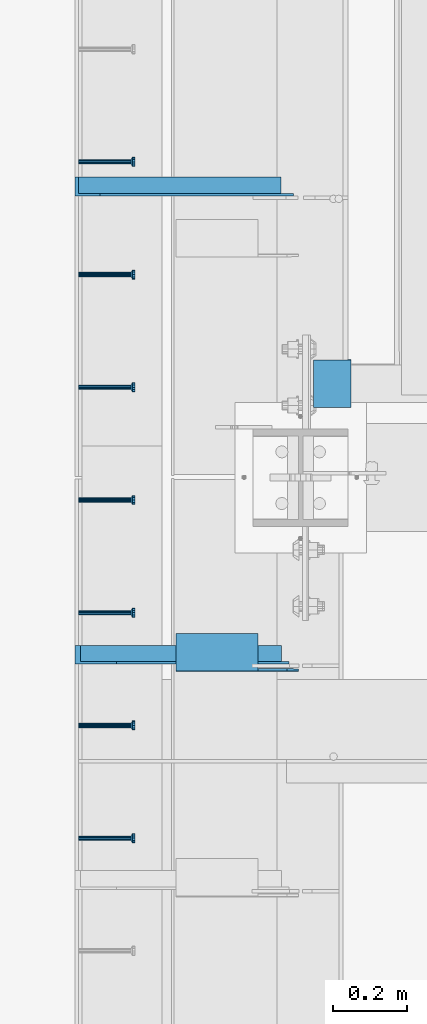
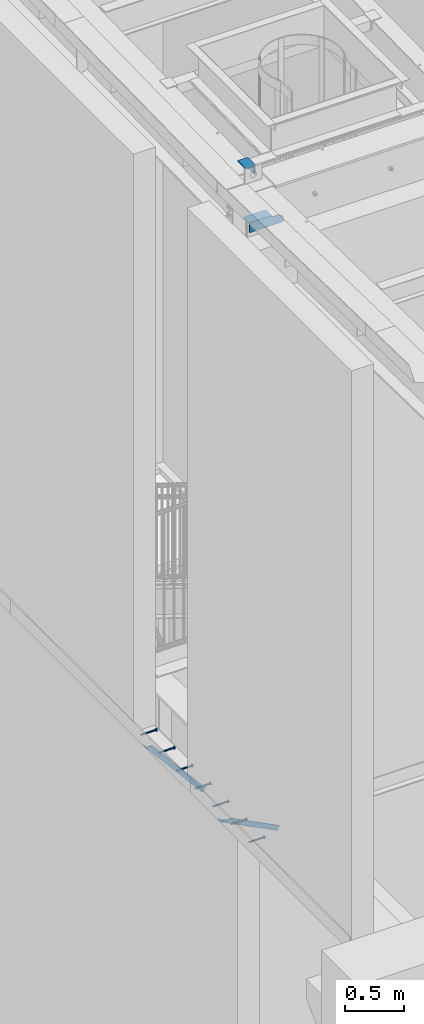
# One storey, part 1254 of 1763: 9 beams, 2 members, 11 elements without a shape of their own.
"""IFC2X3 building model written with IfcOpenShell, lengths in millimetres."""

from ifc_helpers import new_model, si_unit, frame, origin_with_axes, place, context, subcontext, project, spatial, faceted_brep, material, type_object, element, aggregate, save


model = new_model("IFC2X3")

# Units and contexts
model_context = context("Model", 3, precision=1e-05, world=origin_with_axes())
body_context = subcontext(model_context, "Body", "Model", "MODEL_VIEW")
ifc_project = project(units=[si_unit("LENGTHUNIT", "METRE", prefix="MILLI"), si_unit("AREAUNIT", "SQUARE_METRE"), si_unit("VOLUMEUNIT", "CUBIC_METRE"), si_unit("MASSUNIT", "GRAM", prefix="KILO"), si_unit("TIMEUNIT", "SECOND"), si_unit("PLANEANGLEUNIT", "RADIAN"), si_unit("SOLIDANGLEUNIT", "STERADIAN"), si_unit("THERMODYNAMICTEMPERATUREUNIT", "DEGREE_CELSIUS"), si_unit("LUMINOUSINTENSITYUNIT", "LUMEN")], contexts=[model_context])

# Site, building, storey
site_placement = place(None, origin_with_axes())
site = spatial("IfcSite", under=ifc_project, at=site_placement, CompositionType="ELEMENT")
building_placement = place(site_placement, origin_with_axes())
building = spatial("IfcBuilding", under=site, at=building_placement, Name="Undefined", CompositionType="ELEMENT")
storey_placement = place(building_placement, origin_with_axes())
storey = spatial("IfcBuildingStorey", under=building, at=storey_placement, Name="Undefined", CompositionType="ELEMENT", Elevation=0.0)

# Assembly, beam
assembly_1_placement = place(storey_placement, origin_with_axes())
assembly_1 = element("IfcElementAssembly", 1, at=assembly_1_placement, inside=storey, Name="HEADED STUD ANCHOR", AssemblyPlace="NOTDEFINED", PredefinedType="RIGID_FRAME")
ifc_material_1 = material(Name="STEEL/A108")
beam_type_1 = type_object("IfcBeamType", PredefinedType="NOTDEFINED")
beam_1_placement = place(assembly_1_placement, frame((-87975.5122736983, 29048.0750061035, 5268.91250001202), z_axis=(0.0, 0.0, -1.0), x_axis=(1.0, 0.0, 0.0)))
beam_1 = element("IfcBeam", 2, at=beam_1_placement, type_object=beam_type_1, material=ifc_material_1, Name="HEADED STUD ANCHOR", context=body_context, shape_type="Brep", body=[
    faceted_brep([(0.0, -3.1800000667572, 5.5), (0.0, -5.5, 3.1800000667572), (141.732000000002, -5.5, 3.1800000667572), (141.732000000002, -3.1800000667572, 5.5), (0.0, -6.34999999999491, 1.45519152283669e-11), (141.732000000002, -6.34999990463257, 0.0), (0.0, -5.5, -3.1800000667572), (141.732000000002, -5.5, -3.1800000667572), (0.0, -3.1800000667572, -5.5), (141.732000000002, -3.1800000667572, -5.5), (0.0, 0.0, -6.34999990463257), (141.732000000002, 0.0, -6.34999990463257), (0.0, 3.1800000667572, -5.5), (141.732000000002, 3.1800000667572, -5.5), (0.0, 5.5, -3.1800000667572), (141.732000000002, 5.5, -3.1800000667572), (0.0, 6.34999999999491, -2.91038304567337e-11), (141.732000000002, 6.34999990463257, 0.0), (0.0, 5.5, 3.1800000667572), (141.732000000002, 5.5, 3.1800000667572), (0.0, 3.1800000667572, 5.5), (141.732000000002, 3.1800000667572, 5.5), (0.0, 0.0, 6.34999990463257), (141.732000000002, 0.0, 6.34999990463257), (144.780000000001, -10.9899997711182, 6.34999990463257), (144.780000000001, -6.34000015258789, 10.9899997711182), (144.780000000001, -12.6999998092651, 0.0), (144.780000000001, -10.9899997711182, -6.34999990463257), (144.780000000001, -6.34000015258789, -10.9899997711182), (144.780000000001, 0.0, -12.6899995803833), (144.780000000001, 6.34000015258789, -10.9899997711182), (144.780000000001, 10.9899997711182, -6.34999990463257), (144.780000000001, 12.6999998092651, 0.0), (144.780000000001, 10.9899997711182, 6.34999990463257), (144.780000000001, 6.34000015258789, 10.9899997711182), (144.780000000001, 0.0, 12.6899995803833), (152.400000000001, -10.9899997711182, 6.34999990463257), (152.400000000001, -6.34000015258789, 10.9899997711182), (152.400000000001, -12.6999998092651, 0.0), (152.400000000001, -10.9899997711182, -6.34999990463257), (152.400000000001, -6.34000015258789, -10.9899997711182), (152.400000000001, 0.0, -12.6899995803833), (152.400000000001, 6.34000015258789, -10.9899997711182), (152.400000000001, 10.9899997711182, -6.34999990463257), (152.400000000001, 12.6999998092651, 0.0), (152.400000000001, 10.9899997711182, 6.34999990463257), (152.400000000001, 6.34000015258789, 10.9899997711182), (152.400000000001, 0.0, 12.6899995803833)], [[[0, 1, 2, 3]], [[1, 4, 5, 2]], [[4, 6, 7, 5]], [[6, 8, 9, 7]], [[8, 10, 11, 9]], [[10, 12, 13, 11]], [[12, 14, 15, 13]], [[14, 16, 17, 15]], [[16, 18, 19, 17]], [[18, 20, 21, 19]], [[20, 22, 23, 21]], [[22, 0, 3, 23]], [[22, 20, 18, 16, 14, 12, 10, 8, 6, 4, 1, 0]], [[3, 2, 24, 25]], [[2, 5, 26, 24]], [[5, 7, 27, 26]], [[7, 9, 28, 27]], [[9, 11, 29, 28]], [[11, 13, 30, 29]], [[13, 15, 31, 30]], [[15, 17, 32, 31]], [[17, 19, 33, 32]], [[19, 21, 34, 33]], [[21, 23, 35, 34]], [[23, 3, 25, 35]], [[25, 24, 36, 37]], [[24, 26, 38, 36]], [[26, 27, 39, 38]], [[27, 28, 40, 39]], [[28, 29, 41, 40]], [[29, 30, 42, 41]], [[30, 31, 43, 42]], [[31, 32, 44, 43]], [[32, 33, 45, 44]], [[33, 34, 46, 45]], [[34, 35, 47, 46]], [[35, 25, 37, 47]], [[38, 39, 40, 41, 42, 43, 44, 45, 46, 47, 37, 36]]]),
])
aggregate(assembly_1, [beam_1])

assembly_2_placement = place(storey_placement, origin_with_axes())
assembly_2 = element("IfcElementAssembly", 3, at=assembly_2_placement, inside=storey, Name="HEADED STUD ANCHOR", AssemblyPlace="NOTDEFINED", PredefinedType="RIGID_FRAME")
beam_2_placement = place(assembly_2_placement, frame((-87975.5122736983, 29352.8750061035, 5268.91250001202), z_axis=(0.0, 0.0, -1.0), x_axis=(1.0, 0.0, 0.0)))
beam_2 = element("IfcBeam", 4, at=beam_2_placement, type_object=beam_type_1, material=ifc_material_1, Name="HEADED STUD ANCHOR", context=body_context, shape_type="Brep", body=[
    faceted_brep([(0.0, -3.1800000667572, 5.5), (0.0, -5.5, 3.1800000667572), (141.732000000002, -5.5, 3.1800000667572), (141.732000000002, -3.1800000667572, 5.5), (0.0, -6.34999999999491, 1.45519152283669e-11), (141.732000000002, -6.34999990463257, 0.0), (0.0, -5.5, -3.1800000667572), (141.732000000002, -5.5, -3.1800000667572), (0.0, -3.1800000667572, -5.5), (141.732000000002, -3.1800000667572, -5.5), (0.0, 0.0, -6.34999990463257), (141.732000000002, 0.0, -6.34999990463257), (0.0, 3.1800000667572, -5.5), (141.732000000002, 3.1800000667572, -5.5), (0.0, 5.5, -3.1800000667572), (141.732000000002, 5.5, -3.1800000667572), (0.0, 6.34999999999491, -2.91038304567337e-11), (141.732000000002, 6.34999990463257, 0.0), (0.0, 5.5, 3.1800000667572), (141.732000000002, 5.5, 3.1800000667572), (0.0, 3.1800000667572, 5.5), (141.732000000002, 3.1800000667572, 5.5), (0.0, 0.0, 6.34999990463257), (141.732000000002, 0.0, 6.34999990463257), (144.780000000001, -10.9899997711182, 6.34999990463257), (144.780000000001, -6.34000015258789, 10.9899997711182), (144.780000000001, -12.6999998092651, 0.0), (144.780000000001, -10.9899997711182, -6.34999990463257), (144.780000000001, -6.34000015258789, -10.9899997711182), (144.780000000001, 0.0, -12.6899995803833), (144.780000000001, 6.34000015258789, -10.9899997711182), (144.780000000001, 10.9899997711182, -6.34999990463257), (144.780000000001, 12.6999998092651, 0.0), (144.780000000001, 10.9899997711182, 6.34999990463257), (144.780000000001, 6.34000015258789, 10.9899997711182), (144.780000000001, 0.0, 12.6899995803833), (152.400000000001, -10.9899997711182, 6.34999990463257), (152.400000000001, -6.34000015258789, 10.9899997711182), (152.400000000001, -12.6999998092651, 0.0), (152.400000000001, -10.9899997711182, -6.34999990463257), (152.400000000001, -6.34000015258789, -10.9899997711182), (152.400000000001, 0.0, -12.6899995803833), (152.400000000001, 6.34000015258789, -10.9899997711182), (152.400000000001, 10.9899997711182, -6.34999990463257), (152.400000000001, 12.6999998092651, 0.0), (152.400000000001, 10.9899997711182, 6.34999990463257), (152.400000000001, 6.34000015258789, 10.9899997711182), (152.400000000001, 0.0, 12.6899995803833)], [[[0, 1, 2, 3]], [[1, 4, 5, 2]], [[4, 6, 7, 5]], [[6, 8, 9, 7]], [[8, 10, 11, 9]], [[10, 12, 13, 11]], [[12, 14, 15, 13]], [[14, 16, 17, 15]], [[16, 18, 19, 17]], [[18, 20, 21, 19]], [[20, 22, 23, 21]], [[22, 0, 3, 23]], [[22, 20, 18, 16, 14, 12, 10, 8, 6, 4, 1, 0]], [[3, 2, 24, 25]], [[2, 5, 26, 24]], [[5, 7, 27, 26]], [[7, 9, 28, 27]], [[9, 11, 29, 28]], [[11, 13, 30, 29]], [[13, 15, 31, 30]], [[15, 17, 32, 31]], [[17, 19, 33, 32]], [[19, 21, 34, 33]], [[21, 23, 35, 34]], [[23, 3, 25, 35]], [[25, 24, 36, 37]], [[24, 26, 38, 36]], [[26, 27, 39, 38]], [[27, 28, 40, 39]], [[28, 29, 41, 40]], [[29, 30, 42, 41]], [[30, 31, 43, 42]], [[31, 32, 44, 43]], [[32, 33, 45, 44]], [[33, 34, 46, 45]], [[34, 35, 47, 46]], [[35, 25, 37, 47]], [[38, 39, 40, 41, 42, 43, 44, 45, 46, 47, 37, 36]]]),
])
aggregate(assembly_2, [beam_2])

assembly_3_placement = place(storey_placement, origin_with_axes())
assembly_3 = element("IfcElementAssembly", 5, at=assembly_3_placement, inside=storey, Name="HEADED STUD ANCHOR", AssemblyPlace="NOTDEFINED", PredefinedType="RIGID_FRAME")
beam_3_placement = place(assembly_3_placement, frame((-87975.5122736983, 29657.6750061035, 5268.91250001202), z_axis=(0.0, 0.0, -1.0), x_axis=(1.0, 0.0, 0.0)))
beam_3 = element("IfcBeam", 6, at=beam_3_placement, type_object=beam_type_1, material=ifc_material_1, Name="HEADED STUD ANCHOR", context=body_context, shape_type="Brep", body=[
    faceted_brep([(0.0, -3.1800000667572, 5.5), (0.0, -5.5, 3.1800000667572), (141.732000000002, -5.5, 3.1800000667572), (141.732000000002, -3.1800000667572, 5.5), (0.0, -6.34999999999491, 1.45519152283669e-11), (141.732000000002, -6.34999990463257, 0.0), (0.0, -5.5, -3.1800000667572), (141.732000000002, -5.5, -3.1800000667572), (0.0, -3.1800000667572, -5.5), (141.732000000002, -3.1800000667572, -5.5), (0.0, 0.0, -6.34999990463257), (141.732000000002, 0.0, -6.34999990463257), (0.0, 3.1800000667572, -5.5), (141.732000000002, 3.1800000667572, -5.5), (0.0, 5.5, -3.1800000667572), (141.732000000002, 5.5, -3.1800000667572), (0.0, 6.34999999999491, -2.91038304567337e-11), (141.732000000002, 6.34999990463257, 0.0), (0.0, 5.5, 3.1800000667572), (141.732000000002, 5.5, 3.1800000667572), (0.0, 3.1800000667572, 5.5), (141.732000000002, 3.1800000667572, 5.5), (0.0, 0.0, 6.34999990463257), (141.732000000002, 0.0, 6.34999990463257), (144.780000000001, -10.9899997711182, 6.34999990463257), (144.780000000001, -6.34000015258789, 10.9899997711182), (144.780000000001, -12.6999998092651, 0.0), (144.780000000001, -10.9899997711182, -6.34999990463257), (144.780000000001, -6.34000015258789, -10.9899997711182), (144.780000000001, 0.0, -12.6899995803833), (144.780000000001, 6.34000015258789, -10.9899997711182), (144.780000000001, 10.9899997711182, -6.34999990463257), (144.780000000001, 12.6999998092651, 0.0), (144.780000000001, 10.9899997711182, 6.34999990463257), (144.780000000001, 6.34000015258789, 10.9899997711182), (144.780000000001, 0.0, 12.6899995803833), (152.400000000001, -10.9899997711182, 6.34999990463257), (152.400000000001, -6.34000015258789, 10.9899997711182), (152.400000000001, -12.6999998092651, 0.0), (152.400000000001, -10.9899997711182, -6.34999990463257), (152.400000000001, -6.34000015258789, -10.9899997711182), (152.400000000001, 0.0, -12.6899995803833), (152.400000000001, 6.34000015258789, -10.9899997711182), (152.400000000001, 10.9899997711182, -6.34999990463257), (152.400000000001, 12.6999998092651, 0.0), (152.400000000001, 10.9899997711182, 6.34999990463257), (152.400000000001, 6.34000015258789, 10.9899997711182), (152.400000000001, 0.0, 12.6899995803833)], [[[0, 1, 2, 3]], [[1, 4, 5, 2]], [[4, 6, 7, 5]], [[6, 8, 9, 7]], [[8, 10, 11, 9]], [[10, 12, 13, 11]], [[12, 14, 15, 13]], [[14, 16, 17, 15]], [[16, 18, 19, 17]], [[18, 20, 21, 19]], [[20, 22, 23, 21]], [[22, 0, 3, 23]], [[22, 20, 18, 16, 14, 12, 10, 8, 6, 4, 1, 0]], [[3, 2, 24, 25]], [[2, 5, 26, 24]], [[5, 7, 27, 26]], [[7, 9, 28, 27]], [[9, 11, 29, 28]], [[11, 13, 30, 29]], [[13, 15, 31, 30]], [[15, 17, 32, 31]], [[17, 19, 33, 32]], [[19, 21, 34, 33]], [[21, 23, 35, 34]], [[23, 3, 25, 35]], [[25, 24, 36, 37]], [[24, 26, 38, 36]], [[26, 27, 39, 38]], [[27, 28, 40, 39]], [[28, 29, 41, 40]], [[29, 30, 42, 41]], [[30, 31, 43, 42]], [[31, 32, 44, 43]], [[32, 33, 45, 44]], [[33, 34, 46, 45]], [[34, 35, 47, 46]], [[35, 25, 37, 47]], [[38, 39, 40, 41, 42, 43, 44, 45, 46, 47, 37, 36]]]),
])
aggregate(assembly_3, [beam_3])

assembly_4_placement = place(storey_placement, origin_with_axes())
assembly_4 = element("IfcElementAssembly", 7, at=assembly_4_placement, inside=storey, Name="HEADED STUD ANCHOR", AssemblyPlace="NOTDEFINED", PredefinedType="RIGID_FRAME")
beam_4_placement = place(assembly_4_placement, frame((-87975.5122736983, 29962.4750061035, 5268.91250001202), z_axis=(0.0, 0.0, -1.0), x_axis=(1.0, 0.0, 0.0)))
beam_4 = element("IfcBeam", 8, at=beam_4_placement, type_object=beam_type_1, material=ifc_material_1, Name="HEADED STUD ANCHOR", context=body_context, shape_type="Brep", body=[
    faceted_brep([(0.0, -3.1800000667572, 5.5), (0.0, -5.5, 3.1800000667572), (141.732000000002, -5.5, 3.1800000667572), (141.732000000002, -3.1800000667572, 5.5), (0.0, -6.34999999999491, 1.45519152283669e-11), (141.732000000002, -6.34999990463257, 0.0), (0.0, -5.5, -3.1800000667572), (141.732000000002, -5.5, -3.1800000667572), (0.0, -3.1800000667572, -5.5), (141.732000000002, -3.1800000667572, -5.5), (0.0, 0.0, -6.34999990463257), (141.732000000002, 0.0, -6.34999990463257), (0.0, 3.1800000667572, -5.5), (141.732000000002, 3.1800000667572, -5.5), (0.0, 5.5, -3.1800000667572), (141.732000000002, 5.5, -3.1800000667572), (0.0, 6.34999999999491, -2.91038304567337e-11), (141.732000000002, 6.34999990463257, 0.0), (0.0, 5.5, 3.1800000667572), (141.732000000002, 5.5, 3.1800000667572), (0.0, 3.1800000667572, 5.5), (141.732000000002, 3.1800000667572, 5.5), (0.0, 0.0, 6.34999990463257), (141.732000000002, 0.0, 6.34999990463257), (144.780000000001, -10.9899997711182, 6.34999990463257), (144.780000000001, -6.34000015258789, 10.9899997711182), (144.780000000001, -12.6999998092651, 0.0), (144.780000000001, -10.9899997711182, -6.34999990463257), (144.780000000001, -6.34000015258789, -10.9899997711182), (144.780000000001, 0.0, -12.6899995803833), (144.780000000001, 6.34000015258789, -10.9899997711182), (144.780000000001, 10.9899997711182, -6.34999990463257), (144.780000000001, 12.6999998092651, 0.0), (144.780000000001, 10.9899997711182, 6.34999990463257), (144.780000000001, 6.34000015258789, 10.9899997711182), (144.780000000001, 0.0, 12.6899995803833), (152.400000000001, -10.9899997711182, 6.34999990463257), (152.400000000001, -6.34000015258789, 10.9899997711182), (152.400000000001, -12.6999998092651, 0.0), (152.400000000001, -10.9899997711182, -6.34999990463257), (152.400000000001, -6.34000015258789, -10.9899997711182), (152.400000000001, 0.0, -12.6899995803833), (152.400000000001, 6.34000015258789, -10.9899997711182), (152.400000000001, 10.9899997711182, -6.34999990463257), (152.400000000001, 12.6999998092651, 0.0), (152.400000000001, 10.9899997711182, 6.34999990463257), (152.400000000001, 6.34000015258789, 10.9899997711182), (152.400000000001, 0.0, 12.6899995803833)], [[[0, 1, 2, 3]], [[1, 4, 5, 2]], [[4, 6, 7, 5]], [[6, 8, 9, 7]], [[8, 10, 11, 9]], [[10, 12, 13, 11]], [[12, 14, 15, 13]], [[14, 16, 17, 15]], [[16, 18, 19, 17]], [[18, 20, 21, 19]], [[20, 22, 23, 21]], [[22, 0, 3, 23]], [[22, 20, 18, 16, 14, 12, 10, 8, 6, 4, 1, 0]], [[3, 2, 24, 25]], [[2, 5, 26, 24]], [[5, 7, 27, 26]], [[7, 9, 28, 27]], [[9, 11, 29, 28]], [[11, 13, 30, 29]], [[13, 15, 31, 30]], [[15, 17, 32, 31]], [[17, 19, 33, 32]], [[19, 21, 34, 33]], [[21, 23, 35, 34]], [[23, 3, 25, 35]], [[25, 24, 36, 37]], [[24, 26, 38, 36]], [[26, 27, 39, 38]], [[27, 28, 40, 39]], [[28, 29, 41, 40]], [[29, 30, 42, 41]], [[30, 31, 43, 42]], [[31, 32, 44, 43]], [[32, 33, 45, 44]], [[33, 34, 46, 45]], [[34, 35, 47, 46]], [[35, 25, 37, 47]], [[38, 39, 40, 41, 42, 43, 44, 45, 46, 47, 37, 36]]]),
])
aggregate(assembly_4, [beam_4])

assembly_5_placement = place(storey_placement, origin_with_axes())
assembly_5 = element("IfcElementAssembly", 9, at=assembly_5_placement, inside=storey, Name="HEADED STUD ANCHOR", AssemblyPlace="NOTDEFINED", PredefinedType="RIGID_FRAME")
beam_5_placement = place(assembly_5_placement, frame((-87975.5122736983, 30267.2750061035, 5268.91250001202), z_axis=(0.0, 0.0, -1.0), x_axis=(1.0, 0.0, 0.0)))
beam_5 = element("IfcBeam", 10, at=beam_5_placement, type_object=beam_type_1, material=ifc_material_1, Name="HEADED STUD ANCHOR", context=body_context, shape_type="Brep", body=[
    faceted_brep([(0.0, -3.1800000667572, 5.5), (0.0, -5.5, 3.1800000667572), (141.732000000002, -5.5, 3.1800000667572), (141.732000000002, -3.1800000667572, 5.5), (0.0, -6.34999999999491, 1.45519152283669e-11), (141.732000000002, -6.34999990463257, 0.0), (0.0, -5.5, -3.1800000667572), (141.732000000002, -5.5, -3.1800000667572), (0.0, -3.1800000667572, -5.5), (141.732000000002, -3.1800000667572, -5.5), (0.0, 0.0, -6.34999990463257), (141.732000000002, 0.0, -6.34999990463257), (0.0, 3.1800000667572, -5.5), (141.732000000002, 3.1800000667572, -5.5), (0.0, 5.5, -3.1800000667572), (141.732000000002, 5.5, -3.1800000667572), (0.0, 6.34999999999491, -2.91038304567337e-11), (141.732000000002, 6.34999990463257, 0.0), (0.0, 5.5, 3.1800000667572), (141.732000000002, 5.5, 3.1800000667572), (0.0, 3.1800000667572, 5.5), (141.732000000002, 3.1800000667572, 5.5), (0.0, 0.0, 6.34999990463257), (141.732000000002, 0.0, 6.34999990463257), (144.780000000001, -10.9899997711182, 6.34999990463257), (144.780000000001, -6.34000015258789, 10.9899997711182), (144.780000000001, -12.6999998092651, 0.0), (144.780000000001, -10.9899997711182, -6.34999990463257), (144.780000000001, -6.34000015258789, -10.9899997711182), (144.780000000001, 0.0, -12.6899995803833), (144.780000000001, 6.34000015258789, -10.9899997711182), (144.780000000001, 10.9899997711182, -6.34999990463257), (144.780000000001, 12.6999998092651, 0.0), (144.780000000001, 10.9899997711182, 6.34999990463257), (144.780000000001, 6.34000015258789, 10.9899997711182), (144.780000000001, 0.0, 12.6899995803833), (152.400000000001, -10.9899997711182, 6.34999990463257), (152.400000000001, -6.34000015258789, 10.9899997711182), (152.400000000001, -12.6999998092651, 0.0), (152.400000000001, -10.9899997711182, -6.34999990463257), (152.400000000001, -6.34000015258789, -10.9899997711182), (152.400000000001, 0.0, -12.6899995803833), (152.400000000001, 6.34000015258789, -10.9899997711182), (152.400000000001, 10.9899997711182, -6.34999990463257), (152.400000000001, 12.6999998092651, 0.0), (152.400000000001, 10.9899997711182, 6.34999990463257), (152.400000000001, 6.34000015258789, 10.9899997711182), (152.400000000001, 0.0, 12.6899995803833)], [[[0, 1, 2, 3]], [[1, 4, 5, 2]], [[4, 6, 7, 5]], [[6, 8, 9, 7]], [[8, 10, 11, 9]], [[10, 12, 13, 11]], [[12, 14, 15, 13]], [[14, 16, 17, 15]], [[16, 18, 19, 17]], [[18, 20, 21, 19]], [[20, 22, 23, 21]], [[22, 0, 3, 23]], [[22, 20, 18, 16, 14, 12, 10, 8, 6, 4, 1, 0]], [[3, 2, 24, 25]], [[2, 5, 26, 24]], [[5, 7, 27, 26]], [[7, 9, 28, 27]], [[9, 11, 29, 28]], [[11, 13, 30, 29]], [[13, 15, 31, 30]], [[15, 17, 32, 31]], [[17, 19, 33, 32]], [[19, 21, 34, 33]], [[21, 23, 35, 34]], [[23, 3, 25, 35]], [[25, 24, 36, 37]], [[24, 26, 38, 36]], [[26, 27, 39, 38]], [[27, 28, 40, 39]], [[28, 29, 41, 40]], [[29, 30, 42, 41]], [[30, 31, 43, 42]], [[31, 32, 44, 43]], [[32, 33, 45, 44]], [[33, 34, 46, 45]], [[34, 35, 47, 46]], [[35, 25, 37, 47]], [[38, 39, 40, 41, 42, 43, 44, 45, 46, 47, 37, 36]]]),
])
aggregate(assembly_5, [beam_5])

assembly_6_placement = place(storey_placement, origin_with_axes())
assembly_6 = element("IfcElementAssembly", 11, at=assembly_6_placement, inside=storey, Name="HEADED STUD ANCHOR", AssemblyPlace="NOTDEFINED", PredefinedType="RIGID_FRAME")
beam_6_placement = place(assembly_6_placement, frame((-87975.5122736983, 30572.0750061035, 5268.91250001202), z_axis=(0.0, 0.0, -1.0), x_axis=(1.0, 0.0, 0.0)))
beam_6 = element("IfcBeam", 12, at=beam_6_placement, type_object=beam_type_1, material=ifc_material_1, Name="HEADED STUD ANCHOR", context=body_context, shape_type="Brep", body=[
    faceted_brep([(0.0, -3.1800000667572, 5.5), (0.0, -5.5, 3.1800000667572), (141.732000000002, -5.5, 3.1800000667572), (141.732000000002, -3.1800000667572, 5.5), (0.0, -6.34999999999491, 1.45519152283669e-11), (141.732000000002, -6.34999990463257, 0.0), (0.0, -5.5, -3.1800000667572), (141.732000000002, -5.5, -3.1800000667572), (0.0, -3.1800000667572, -5.5), (141.732000000002, -3.1800000667572, -5.5), (0.0, 0.0, -6.34999990463257), (141.732000000002, 0.0, -6.34999990463257), (0.0, 3.1800000667572, -5.5), (141.732000000002, 3.1800000667572, -5.5), (0.0, 5.5, -3.1800000667572), (141.732000000002, 5.5, -3.1800000667572), (0.0, 6.34999999999491, -2.91038304567337e-11), (141.732000000002, 6.34999990463257, 0.0), (0.0, 5.5, 3.1800000667572), (141.732000000002, 5.5, 3.1800000667572), (0.0, 3.1800000667572, 5.5), (141.732000000002, 3.1800000667572, 5.5), (0.0, 0.0, 6.34999990463257), (141.732000000002, 0.0, 6.34999990463257), (144.780000000001, -10.9899997711182, 6.34999990463257), (144.780000000001, -6.34000015258789, 10.9899997711182), (144.780000000001, -12.6999998092651, 0.0), (144.780000000001, -10.9899997711182, -6.34999990463257), (144.780000000001, -6.34000015258789, -10.9899997711182), (144.780000000001, 0.0, -12.6899995803833), (144.780000000001, 6.34000015258789, -10.9899997711182), (144.780000000001, 10.9899997711182, -6.34999990463257), (144.780000000001, 12.6999998092651, 0.0), (144.780000000001, 10.9899997711182, 6.34999990463257), (144.780000000001, 6.34000015258789, 10.9899997711182), (144.780000000001, 0.0, 12.6899995803833), (152.400000000001, -10.9899997711182, 6.34999990463257), (152.400000000001, -6.34000015258789, 10.9899997711182), (152.400000000001, -12.6999998092651, 0.0), (152.400000000001, -10.9899997711182, -6.34999990463257), (152.400000000001, -6.34000015258789, -10.9899997711182), (152.400000000001, 0.0, -12.6899995803833), (152.400000000001, 6.34000015258789, -10.9899997711182), (152.400000000001, 10.9899997711182, -6.34999990463257), (152.400000000001, 12.6999998092651, 0.0), (152.400000000001, 10.9899997711182, 6.34999990463257), (152.400000000001, 6.34000015258789, 10.9899997711182), (152.400000000001, 0.0, 12.6899995803833)], [[[0, 1, 2, 3]], [[1, 4, 5, 2]], [[4, 6, 7, 5]], [[6, 8, 9, 7]], [[8, 10, 11, 9]], [[10, 12, 13, 11]], [[12, 14, 15, 13]], [[14, 16, 17, 15]], [[16, 18, 19, 17]], [[18, 20, 21, 19]], [[20, 22, 23, 21]], [[22, 0, 3, 23]], [[22, 20, 18, 16, 14, 12, 10, 8, 6, 4, 1, 0]], [[3, 2, 24, 25]], [[2, 5, 26, 24]], [[5, 7, 27, 26]], [[7, 9, 28, 27]], [[9, 11, 29, 28]], [[11, 13, 30, 29]], [[13, 15, 31, 30]], [[15, 17, 32, 31]], [[17, 19, 33, 32]], [[19, 21, 34, 33]], [[21, 23, 35, 34]], [[23, 3, 25, 35]], [[25, 24, 36, 37]], [[24, 26, 38, 36]], [[26, 27, 39, 38]], [[27, 28, 40, 39]], [[28, 29, 41, 40]], [[29, 30, 42, 41]], [[30, 31, 43, 42]], [[31, 32, 44, 43]], [[32, 33, 45, 44]], [[33, 34, 46, 45]], [[34, 35, 47, 46]], [[35, 25, 37, 47]], [[38, 39, 40, 41, 42, 43, 44, 45, 46, 47, 37, 36]]]),
])
aggregate(assembly_6, [beam_6])

assembly_7_placement = place(storey_placement, origin_with_axes())
assembly_7 = element("IfcElementAssembly", 13, at=assembly_7_placement, inside=storey, Name="HEADED STUD ANCHOR", AssemblyPlace="NOTDEFINED", PredefinedType="RIGID_FRAME")
beam_7_placement = place(assembly_7_placement, frame((-87975.5122736983, 30876.8750061035, 5268.91250001202), z_axis=(0.0, 0.0, -1.0), x_axis=(1.0, 0.0, 0.0)))
beam_7 = element("IfcBeam", 14, at=beam_7_placement, type_object=beam_type_1, material=ifc_material_1, Name="HEADED STUD ANCHOR", context=body_context, shape_type="Brep", body=[
    faceted_brep([(0.0, -3.1800000667572, 5.5), (0.0, -5.5, 3.1800000667572), (141.732000000002, -5.5, 3.1800000667572), (141.732000000002, -3.1800000667572, 5.5), (0.0, -6.34999999999491, 1.45519152283669e-11), (141.732000000002, -6.34999990463257, 0.0), (0.0, -5.5, -3.1800000667572), (141.732000000002, -5.5, -3.1800000667572), (0.0, -3.1800000667572, -5.5), (141.732000000002, -3.1800000667572, -5.5), (0.0, 0.0, -6.34999990463257), (141.732000000002, 0.0, -6.34999990463257), (0.0, 3.1800000667572, -5.5), (141.732000000002, 3.1800000667572, -5.5), (0.0, 5.5, -3.1800000667572), (141.732000000002, 5.5, -3.1800000667572), (0.0, 6.34999999999491, -2.91038304567337e-11), (141.732000000002, 6.34999990463257, 0.0), (0.0, 5.5, 3.1800000667572), (141.732000000002, 5.5, 3.1800000667572), (0.0, 3.1800000667572, 5.5), (141.732000000002, 3.1800000667572, 5.5), (0.0, 0.0, 6.34999990463257), (141.732000000002, 0.0, 6.34999990463257), (144.780000000001, -10.9899997711182, 6.34999990463257), (144.780000000001, -6.34000015258789, 10.9899997711182), (144.780000000001, -12.6999998092651, 0.0), (144.780000000001, -10.9899997711182, -6.34999990463257), (144.780000000001, -6.34000015258789, -10.9899997711182), (144.780000000001, 0.0, -12.6899995803833), (144.780000000001, 6.34000015258789, -10.9899997711182), (144.780000000001, 10.9899997711182, -6.34999990463257), (144.780000000001, 12.6999998092651, 0.0), (144.780000000001, 10.9899997711182, 6.34999990463257), (144.780000000001, 6.34000015258789, 10.9899997711182), (144.780000000001, 0.0, 12.6899995803833), (152.400000000001, -10.9899997711182, 6.34999990463257), (152.400000000001, -6.34000015258789, 10.9899997711182), (152.400000000001, -12.6999998092651, 0.0), (152.400000000001, -10.9899997711182, -6.34999990463257), (152.400000000001, -6.34000015258789, -10.9899997711182), (152.400000000001, 0.0, -12.6899995803833), (152.400000000001, 6.34000015258789, -10.9899997711182), (152.400000000001, 10.9899997711182, -6.34999990463257), (152.400000000001, 12.6999998092651, 0.0), (152.400000000001, 10.9899997711182, 6.34999990463257), (152.400000000001, 6.34000015258789, 10.9899997711182), (152.400000000001, 0.0, 12.6899995803833)], [[[0, 1, 2, 3]], [[1, 4, 5, 2]], [[4, 6, 7, 5]], [[6, 8, 9, 7]], [[8, 10, 11, 9]], [[10, 12, 13, 11]], [[12, 14, 15, 13]], [[14, 16, 17, 15]], [[16, 18, 19, 17]], [[18, 20, 21, 19]], [[20, 22, 23, 21]], [[22, 0, 3, 23]], [[22, 20, 18, 16, 14, 12, 10, 8, 6, 4, 1, 0]], [[3, 2, 24, 25]], [[2, 5, 26, 24]], [[5, 7, 27, 26]], [[7, 9, 28, 27]], [[9, 11, 29, 28]], [[11, 13, 30, 29]], [[13, 15, 31, 30]], [[15, 17, 32, 31]], [[17, 19, 33, 32]], [[19, 21, 34, 33]], [[21, 23, 35, 34]], [[23, 3, 25, 35]], [[25, 24, 36, 37]], [[24, 26, 38, 36]], [[26, 27, 39, 38]], [[27, 28, 40, 39]], [[28, 29, 41, 40]], [[29, 30, 42, 41]], [[30, 31, 43, 42]], [[31, 32, 44, 43]], [[32, 33, 45, 44]], [[33, 34, 46, 45]], [[34, 35, 47, 46]], [[35, 25, 37, 47]], [[38, 39, 40, 41, 42, 43, 44, 45, 46, 47, 37, 36]]]),
])
aggregate(assembly_7, [beam_7])

# Assembly, member
assembly_8_placement = place(storey_placement, origin_with_axes())
assembly_8 = element("IfcElementAssembly", 15, at=assembly_8_placement, inside=storey, Name="BEAM", AssemblyPlace="NOTDEFINED", PredefinedType="RIGID_FRAME")
ifc_material_2 = material(Name="STEEL/A36")
member_type = type_object("IfcMemberType", Name="L2X2X1/4", PredefinedType="NOTDEFINED")
member_1_placement = place(assembly_8_placement, frame((-87419.034014091, 29544.16875, 4933.91987315707), z_axis=(0.454620561889228, 0.0, 0.890685210782981), x_axis=(-0.89068521078298, 0.0, 0.45462056188923)))
member_1 = element("IfcMember", 16, at=member_1_placement, type_object=member_type, material=ifc_material_2, Name="ANGLE", ObjectType="L2X2X1/4", context=body_context, shape_type="Brep", body=[
    faceted_brep([(-1.45519152283669e-11, 25.4000000000015, -25.3999999999869), (1.45519152283669e-11, 25.4000000000015, 25.3999999999796), (522.978374042039, 25.4000000000015, 25.3999999980806), (622.504906836693, 25.4000000000015, -25.4000000021188), (1.45519152283669e-11, 19.0499999999993, 25.3999999999796), (522.978374042039, 19.0499999999993, 25.3999999980806), (-7.27595761418343e-12, 19.0499999999993, -19.0499999999956), (610.064090237356, 19.0499999999993, -19.0500000020984), (-7.27595761418343e-12, -25.4000000000015, -19.0499999999956), (610.064090237356, -25.4000000000015, -19.0500000020984), (-1.45519152283669e-11, -25.4000000000015, -25.3999999999869), (622.504906836693, -25.4000000000015, -25.4000000021188)], [[[0, 1, 2, 3]], [[1, 4, 5, 2]], [[4, 6, 7, 5]], [[6, 8, 9, 7]], [[8, 10, 11, 9]], [[10, 0, 3, 11]], [[5, 7, 9, 11, 3, 2]], [[10, 8, 6, 4, 1, 0]]]),
])
aggregate(assembly_8, [member_1])

assembly_9_placement = place(storey_placement, origin_with_axes())
assembly_9 = element("IfcElementAssembly", 17, at=assembly_9_placement, inside=storey, Name="BEAM", AssemblyPlace="NOTDEFINED", PredefinedType="RIGID_FRAME")
member_2_placement = place(assembly_9_placement, frame((-87414.1929584935, 30810.2, 4557.35349338836), z_axis=(0.764183480307171, 0.0, 0.644998921259268), x_axis=(-0.644998921259266, 0.0, 0.764183480307173)))
member_2 = element("IfcMember", 18, at=member_2_placement, type_object=member_type, material=ifc_material_2, Name="ANGLE", ObjectType="L2X2X1/4", context=body_context, shape_type="Brep", body=[
    faceted_brep([(-1.45519152283669e-11, 25.4000000000015, -25.3999999999869), (1.45519152283669e-11, 25.4000000000015, 25.3999999999796), (812.060911532491, 25.4000000000015, 25.400000001966), (854.937976763787, 25.4000000000015, -25.3999999979424), (1.45519152283669e-11, 19.0499999999993, 25.3999999999796), (812.060911532491, 19.0500000000029, 25.400000001966), (-7.27595761418343e-12, 19.0499999999993, -19.0499999999956), (849.578343609872, 19.0500000000029, -19.0499999979511), (-7.27595761418343e-12, -25.4000000000015, -19.0499999999956), (849.578343609872, -25.4000000000015, -19.0499999979511), (-1.45519152283669e-11, -25.4000000000015, -25.3999999999869), (854.937976763787, -25.4000000000015, -25.3999999979424)], [[[0, 1, 2, 3]], [[1, 4, 5, 2]], [[4, 6, 7, 5]], [[6, 8, 9, 7]], [[8, 10, 11, 9]], [[10, 0, 3, 11]], [[5, 7, 9, 11, 3, 2]], [[10, 8, 6, 4, 1, 0]]]),
])
aggregate(assembly_9, [member_2])

# Assembly, beam
assembly_10_placement = place(storey_placement, origin_with_axes())
assembly_10 = element("IfcElementAssembly", 19, at=assembly_10_placement, inside=storey, Name="BEAM", AssemblyPlace="NOTDEFINED", PredefinedType="RIGID_FRAME")
beam_type_2 = type_object("IfcBeamType", Name="L4X4X1/4", PredefinedType="NOTDEFINED")
beam_8_placement = place(assembly_10_placement, frame((-87711.9872706474, 29550.2914959961, 11249.3637698059), z_axis=(0.0, -0.0208942520060009, -0.999781691287208), x_axis=(1.0, 0.0, 0.0)))
beam_8 = element("IfcBeam", 20, at=beam_8_placement, type_object=beam_type_2, material=ifc_material_2, Name="BRACE", ObjectType="L4X4X1/4", context=body_context, shape_type="Brep", body=[
    faceted_brep([(330.993730570859, 44.4500000001281, -1.58750213774329), (299.243734988457, 44.4500000001208, -33.3493444566793), (299.243734988457, 50.8000000001339, -33.3493444612141), (330.993746948254, 50.8000000001412, -1.5875021377451), (1.96450855582952e-10, -50.8000000000338, -44.4499999999534), (2.11002770811319e-10, -50.8000000000357, -50.799999999952), (220.66276795695, -50.800000000163, -50.7999999999502), (220.662761962012, -50.800000000163, -44.4499999999553), (-3.63797880709171e-11, 50.8000000000011, -50.8000000000538), (220.662767915564, 50.8000000001339, -50.7999999999774), (220.662761923406, 44.4500000001208, -44.4499999999807), (220.662751535681, 50.8000000001339, -33.3786578752915), (220.662751538272, 44.4500000001208, -33.3786578752897), (-2.18278728425503e-11, 44.4500000000007, -44.450000000048), (-1.81898940354586e-10, 44.4500000000371, 50.7999999999374), (-1.96450855582952e-10, 50.8000000000393, 50.7999999999374), (330.993731689443, 44.4500000000007, 50.7999999999993), (330.993731689443, 50.7999999999993, 50.7999999999993)], [[[0, 1, 2, 3]], [[4, 5, 6, 7]], [[5, 8, 9, 6]], [[10, 7, 6, 9, 11, 12]], [[13, 4, 7, 10]], [[5, 4, 13, 14, 15, 8]], [[15, 14, 16, 17]], [[17, 16, 0, 3]], [[11, 9, 8, 15, 17, 3, 2]], [[12, 11, 2, 1]], [[16, 14, 13, 10, 12, 1, 0]]]),
])
aggregate(assembly_10, [beam_8])

assembly_11_placement = place(storey_placement, origin_with_axes())
assembly_11 = element("IfcElementAssembly", 21, at=assembly_11_placement, inside=storey, Name="ANGLE", AssemblyPlace="NOTDEFINED", PredefinedType="RIGID_FRAME")
beam_type_3 = type_object("IfcBeamType", Name="L4X4X3/8", PredefinedType="NOTDEFINED")
beam_9_placement = place(assembly_11_placement, frame((-87289.6796875, 30214.0555044737, 11252.5744167864), z_axis=(0.0, 0.0209829029927459, -0.999779834654609), x_axis=(0.0, 0.999779834654609, 0.0209829029927513)))
beam_9 = element("IfcBeam", 22, at=beam_9_placement, type_object=beam_type_3, material=ifc_material_2, Name="ANGLE", ObjectType="L4X4X3/8", context=body_context, shape_type="Brep", body=[
    faceted_brep([(-3.63797880709171e-11, 50.8000000000011, -50.8000000000538), (-1.96450855582952e-10, 50.8000000000393, 50.7999999999374), (127.680357143057, 50.8000000000029, 50.8000000000775), (127.680357142966, 50.8000000000029, -50.7999999998556), (0.0, 41.2749999999996, 50.7999999999993), (127.680357143057, 41.2749999999942, 50.8000000000775), (0.0, 41.2749999999996, -41.2750000000015), (127.680357142981, 41.2749999999942, -41.2749999998596), (0.0, -50.7999999999993, -41.2750000000015), (127.680357142981, -50.8000000000029, -41.2749999998596), (2.11002770811319e-10, -50.8000000000357, -50.799999999952), (127.680357142966, -50.8000000000029, -50.7999999998556)], [[[0, 1, 2, 3]], [[1, 4, 5, 2]], [[4, 6, 7, 5]], [[6, 8, 9, 7]], [[8, 10, 11, 9]], [[10, 0, 3, 11]], [[5, 7, 9, 11, 3, 2]], [[10, 8, 6, 4, 1, 0]]]),
])
aggregate(assembly_11, [beam_9])

save(model, "model.ifc")
